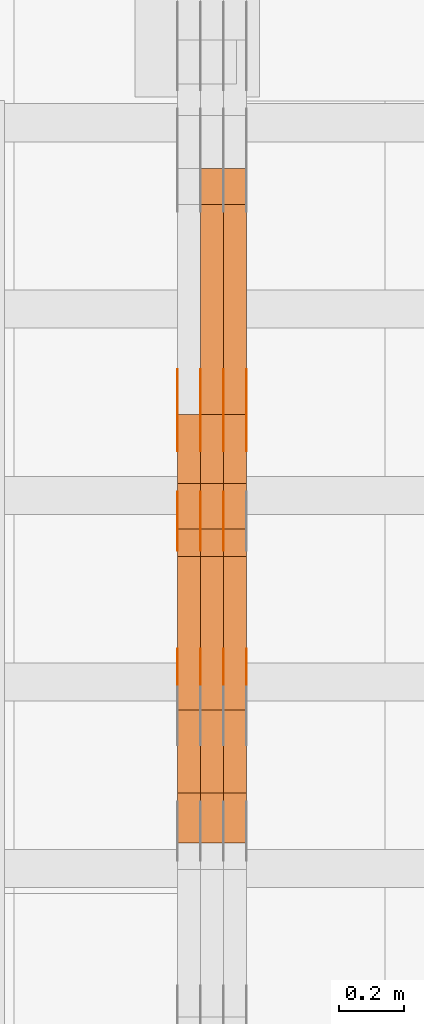
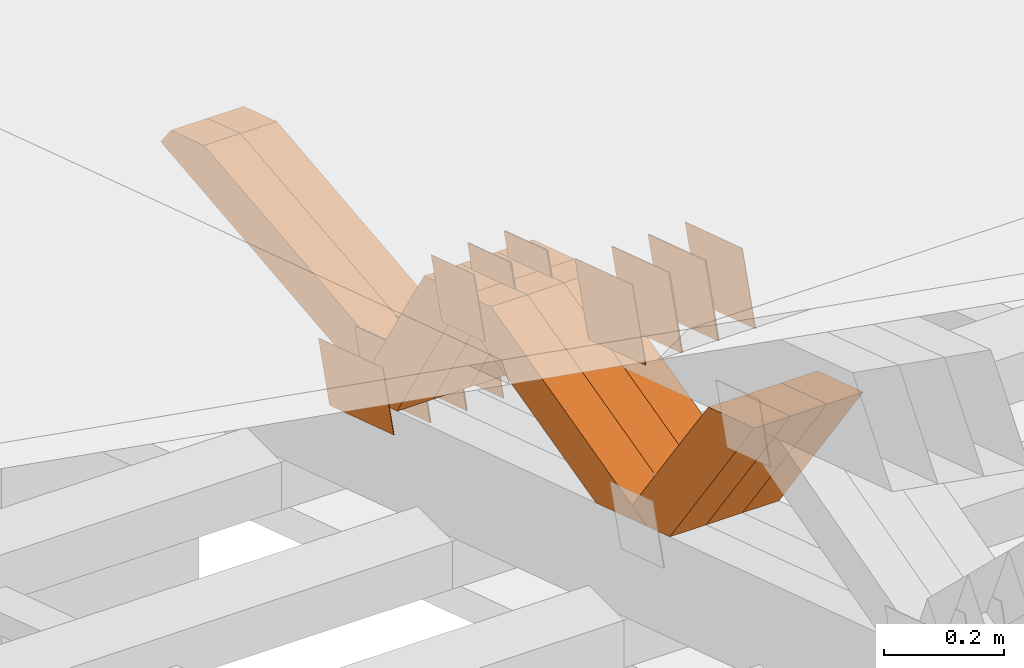
# One storey, part 188 of 385: 28 proxies.
"""IFC2X3 building model written with IfcOpenShell, lengths in millimetres."""

from ifc_helpers import new_model, entity, si_unit, converted_unit, derived_unit, direction, frame, origin, place, context, subcontext, project, spatial, polyline, outline, extrude, source, transform, mapped, material, type_object, type_shapes, element, save


model = new_model("IFC2X3")

# Units and contexts
model_context = context("Model", 3, precision=0.01, world=origin(), true_north=direction((6.12303176911189e-17, 1.0)))
body_context = subcontext(model_context, "Body", "Model", "MODEL_VIEW")
ifc_project = project(units=[si_unit("LENGTHUNIT", "METRE", prefix="MILLI"), si_unit("AREAUNIT", "SQUARE_METRE"), si_unit("VOLUMEUNIT", "CUBIC_METRE"), converted_unit("PLANEANGLEUNIT", "DEGREE", entity("IfcRatioMeasure", 0.0174532925199433), si_unit("PLANEANGLEUNIT", "RADIAN"), dimensions=[0, 0, 0, 0, 0, 0, 0]), si_unit("MASSUNIT", "GRAM", prefix="KILO"), derived_unit("MASSDENSITYUNIT", [(si_unit("MASSUNIT", "GRAM", prefix="KILO"), 1), (si_unit("LENGTHUNIT", "METRE"), -3)]), si_unit("TIMEUNIT", "SECOND"), si_unit("FREQUENCYUNIT", "HERTZ"), si_unit("THERMODYNAMICTEMPERATUREUNIT", "DEGREE_CELSIUS"), derived_unit("THERMALTRANSMITTANCEUNIT", [(si_unit("MASSUNIT", "GRAM", prefix="KILO"), 1), (si_unit("THERMODYNAMICTEMPERATUREUNIT", "KELVIN"), -1), (si_unit("TIMEUNIT", "SECOND"), -3)]), derived_unit("VOLUMETRICFLOWRATEUNIT", [(si_unit("LENGTHUNIT", "METRE"), 3), (si_unit("TIMEUNIT", "SECOND"), -1)]), si_unit("ELECTRICCURRENTUNIT", "AMPERE"), si_unit("ELECTRICVOLTAGEUNIT", "VOLT"), si_unit("POWERUNIT", "WATT"), si_unit("FORCEUNIT", "NEWTON", prefix="KILO"), si_unit("ILLUMINANCEUNIT", "LUX"), si_unit("LUMINOUSFLUXUNIT", "LUMEN"), si_unit("LUMINOUSINTENSITYUNIT", "CANDELA"), derived_unit("USERDEFINED", [(si_unit("MASSUNIT", "GRAM", prefix="KILO"), -1), (si_unit("LENGTHUNIT", "METRE"), -2), (si_unit("TIMEUNIT", "SECOND"), 3), (si_unit("LUMINOUSFLUXUNIT", "LUMEN"), 1)]), derived_unit("LINEARVELOCITYUNIT", [(si_unit("LENGTHUNIT", "METRE"), 1), (si_unit("TIMEUNIT", "SECOND"), -1)]), si_unit("PRESSUREUNIT", "PASCAL"), derived_unit("USERDEFINED", [(si_unit("LENGTHUNIT", "METRE"), -2), (si_unit("MASSUNIT", "GRAM", prefix="KILO"), 1), (si_unit("TIMEUNIT", "SECOND"), -2)])], contexts=[model_context])

# Site, building, storey
site_placement = place(None, origin())
site = spatial("IfcSite", under=ifc_project, at=site_placement, CompositionType="ELEMENT")
building_placement = place(site_placement, origin())
building = spatial("IfcBuilding", under=site, at=building_placement, CompositionType="ELEMENT")
storey_placement = place(building_placement, origin())
storey = spatial("IfcBuildingStorey", under=building, at=storey_placement, Name="Default", CompositionType="ELEMENT", Elevation=0.0)

# Proxies
ifc_material_1 = material(Name="IfcSurfaceStyle #91081")
building_element_proxy_type_1 = type_object("IfcBuildingElementProxyType", PredefinedType="NOTDEFINED", material=ifc_material_1)
shared_shape_1 = source(origin(), body_context, "Body", "SweptSolid", [
    extrude(outline(polyline([(-75.0001163267648, -60.0000309352964), (75.0001029049313, -60.0000309352964), (75.0001068963143, 60.0000309352964), (-75.0000934744807, 60.0000309352964), (-75.0001163267648, -60.0000309352964)])), frame((75.0001143227305, 60.0000309352964, 0.0), z_axis=(0.0, 0.0, 1.0), x_axis=(-1.0, 0.0, 0.0)), (0.0, 0.0, 1.0), 1.3),
])
type_shapes(building_element_proxy_type_1, [shared_shape_1])
proxy_1_placement = place(building_placement, frame((6315.0, 24935.0160969462, 827.753587802763), z_axis=(-1.0, 0.0, 0.0), x_axis=(0.0, -0.951056516295154, 0.309016994374948)))
element("IfcBuildingElementProxy", 1, at=proxy_1_placement, inside=storey, type_object=building_element_proxy_type_1, material=ifc_material_1, context=body_context, shape_type="MappedRepresentation", body=[
    mapped(shared_shape_1, transform((0.0, 0.0, 0.0), scale=1.0)),
])
ifc_material_2 = material(Name="IfcSurfaceStyle #91024")
building_element_proxy_type_2 = type_object("IfcBuildingElementProxyType", PredefinedType="NOTDEFINED", material=ifc_material_2)
shared_shape_2 = source(origin(), body_context, "Body", "SweptSolid", [
    extrude(outline(polyline([(-75.0001163267648, -60.0000309352964), (75.0001029049313, -60.0000309352964), (75.0001068963143, 60.0000309352964), (-75.0000934744807, 60.0000309352964), (-75.0001163267648, -60.0000309352964)])), frame((75.0001143227305, 60.0000309352964, 0.0), z_axis=(0.0, 0.0, 1.0), x_axis=(-1.0, 0.0, 0.0)), (0.0, 0.0, 1.0), 1.3),
])
type_shapes(building_element_proxy_type_2, [shared_shape_2])
proxy_2_placement = place(building_placement, frame((6316.29999999999, 24935.0160969462, 827.753587802763), z_axis=(-1.0, 0.0, 0.0), x_axis=(0.0, -0.951056516295154, 0.309016994374948)))
element("IfcBuildingElementProxy", 2, at=proxy_2_placement, inside=storey, type_object=building_element_proxy_type_2, material=ifc_material_2, context=body_context, shape_type="MappedRepresentation", body=[
    mapped(shared_shape_2, transform((0.0, 0.0, 0.0), scale=1.0)),
])
ifc_material_3 = material(Name="IfcSurfaceStyle #90967")
building_element_proxy_type_3 = type_object("IfcBuildingElementProxyType", PredefinedType="NOTDEFINED", material=ifc_material_3)
shared_shape_3 = source(origin(), body_context, "Body", "SweptSolid", [
    extrude(outline(polyline([(-75.0001163267648, -60.0000309352964), (75.0001029049313, -60.0000309352964), (75.0001068963143, 60.0000309352964), (-75.0000934744807, 60.0000309352964), (-75.0001163267648, -60.0000309352964)])), frame((75.0001143227305, 60.0000309352964, 0.0), z_axis=(0.0, 0.0, 1.0), x_axis=(-1.0, 0.0, 0.0)), (0.0, 0.0, 1.0), 1.29999999999999),
])
type_shapes(building_element_proxy_type_3, [shared_shape_3])
proxy_3_placement = place(building_placement, frame((6245.0, 24935.0160969462, 827.753587802763), z_axis=(-1.0, 0.0, 0.0), x_axis=(0.0, -0.951056516295154, 0.309016994374948)))
element("IfcBuildingElementProxy", 3, at=proxy_3_placement, inside=storey, type_object=building_element_proxy_type_3, material=ifc_material_3, context=body_context, shape_type="MappedRepresentation", body=[
    mapped(shared_shape_3, transform((0.0, 0.0, 0.0), scale=1.0)),
])
ifc_material_4 = material(Name="IfcSurfaceStyle #90910")
building_element_proxy_type_4 = type_object("IfcBuildingElementProxyType", PredefinedType="NOTDEFINED", material=ifc_material_4)
shared_shape_4 = source(origin(), body_context, "Body", "SweptSolid", [
    extrude(outline(polyline([(-75.0001163267648, -60.0000309352964), (75.0001029049313, -60.0000309352964), (75.0001068963143, 60.0000309352964), (-75.0000934744807, 60.0000309352964), (-75.0001163267648, -60.0000309352964)])), frame((75.0001143227305, 60.0000309352964, 0.0), z_axis=(0.0, 0.0, 1.0), x_axis=(-1.0, 0.0, 0.0)), (0.0, 0.0, 1.0), 1.29999999999999),
])
type_shapes(building_element_proxy_type_4, [shared_shape_4])
proxy_4_placement = place(building_placement, frame((6246.29999999999, 24935.0160969462, 827.753587802763), z_axis=(-1.0, 0.0, 0.0), x_axis=(0.0, -0.951056516295154, 0.309016994374948)))
element("IfcBuildingElementProxy", 4, at=proxy_4_placement, inside=storey, type_object=building_element_proxy_type_4, material=ifc_material_4, context=body_context, shape_type="MappedRepresentation", body=[
    mapped(shared_shape_4, transform((0.0, 0.0, 0.0), scale=1.0)),
])
ifc_material_5 = material(Name="IfcSurfaceStyle #90853")
building_element_proxy_type_5 = type_object("IfcBuildingElementProxyType", PredefinedType="NOTDEFINED", material=ifc_material_5)
shared_shape_5 = source(origin(), body_context, "Body", "SweptSolid", [
    extrude(outline(polyline([(-75.0001163267648, -60.0000309352964), (75.0001029049313, -60.0000309352964), (75.0001068963143, 60.0000309352964), (-75.0000934744807, 60.0000309352964), (-75.0001163267648, -60.0000309352964)])), frame((75.0001143227305, 60.0000309352964, 0.0), z_axis=(0.0, 0.0, 1.0), x_axis=(-1.0, 0.0, 0.0)), (0.0, 0.0, 1.0), 1.29999999999999),
])
type_shapes(building_element_proxy_type_5, [shared_shape_5])
proxy_5_placement = place(building_placement, frame((6175.0, 24935.0160969462, 827.753587802763), z_axis=(-1.0, 0.0, 0.0), x_axis=(0.0, -0.951056516295154, 0.309016994374948)))
element("IfcBuildingElementProxy", 5, at=proxy_5_placement, inside=storey, type_object=building_element_proxy_type_5, material=ifc_material_5, context=body_context, shape_type="MappedRepresentation", body=[
    mapped(shared_shape_5, transform((0.0, 0.0, 0.0), scale=1.0)),
])
ifc_material_6 = material(Name="IfcSurfaceStyle #90796")
building_element_proxy_type_6 = type_object("IfcBuildingElementProxyType", PredefinedType="NOTDEFINED", material=ifc_material_6)
shared_shape_6 = source(origin(), body_context, "Body", "SweptSolid", [
    extrude(outline(polyline([(-112.50003853564, -60.0000121429077), (112.50002982902, -60.0000121429077), (112.500043250865, 60.0000121429077), (-112.500034544245, 60.0000121429077), (-112.50003853564, -60.0000121429077)])), frame((112.500056021398, 60.0000121429077, 0.0), z_axis=(0.0, 0.0, 1.0), x_axis=(-1.0, 0.0, 0.0)), (0.0, 0.0, 1.0), 1.3),
])
type_shapes(building_element_proxy_type_6, [shared_shape_6])
proxy_6_placement = place(building_placement, frame((6386.29999999999, 25310.2182710495, 430.675738123044), z_axis=(-1.0, 0.0, 0.0), x_axis=(0.0, -0.951056516295124, 0.309016994375039)))
element("IfcBuildingElementProxy", 6, at=proxy_6_placement, inside=storey, type_object=building_element_proxy_type_6, material=ifc_material_6, context=body_context, shape_type="MappedRepresentation", body=[
    mapped(shared_shape_6, transform((0.0, 0.0, 0.0), scale=1.0)),
])
ifc_material_7 = material(Name="IfcSurfaceStyle #90739")
building_element_proxy_type_7 = type_object("IfcBuildingElementProxyType", PredefinedType="NOTDEFINED", material=ifc_material_7)
shared_shape_7 = source(origin(), body_context, "Body", "SweptSolid", [
    extrude(outline(polyline([(-112.50003853564, -60.0000121429077), (112.50002982902, -60.0000121429077), (112.500043250865, 60.0000121429077), (-112.500034544245, 60.0000121429077), (-112.50003853564, -60.0000121429077)])), frame((112.500056021398, 60.0000121429077, 0.0), z_axis=(0.0, 0.0, 1.0), x_axis=(-1.0, 0.0, 0.0)), (0.0, 0.0, 1.0), 1.3),
])
type_shapes(building_element_proxy_type_7, [shared_shape_7])
proxy_7_placement = place(building_placement, frame((6315.0, 25310.2182710495, 430.675738123044), z_axis=(-1.0, 0.0, 0.0), x_axis=(0.0, -0.951056516295124, 0.309016994375039)))
element("IfcBuildingElementProxy", 7, at=proxy_7_placement, inside=storey, type_object=building_element_proxy_type_7, material=ifc_material_7, context=body_context, shape_type="MappedRepresentation", body=[
    mapped(shared_shape_7, transform((0.0, 0.0, 0.0), scale=1.0)),
])
ifc_material_8 = material(Name="IfcSurfaceStyle #90682")
building_element_proxy_type_8 = type_object("IfcBuildingElementProxyType", PredefinedType="NOTDEFINED", material=ifc_material_8)
shared_shape_8 = source(origin(), body_context, "Body", "SweptSolid", [
    extrude(outline(polyline([(-112.50003853564, -60.0000121429077), (112.50002982902, -60.0000121429077), (112.500043250865, 60.0000121429077), (-112.500034544245, 60.0000121429077), (-112.50003853564, -60.0000121429077)])), frame((112.500056021398, 60.0000121429077, 0.0), z_axis=(0.0, 0.0, 1.0), x_axis=(-1.0, 0.0, 0.0)), (0.0, 0.0, 1.0), 1.3),
])
type_shapes(building_element_proxy_type_8, [shared_shape_8])
proxy_8_placement = place(building_placement, frame((6316.29999999999, 25310.2182710495, 430.675738123044), z_axis=(-1.0, 0.0, 0.0), x_axis=(0.0, -0.951056516295124, 0.309016994375039)))
element("IfcBuildingElementProxy", 8, at=proxy_8_placement, inside=storey, type_object=building_element_proxy_type_8, material=ifc_material_8, context=body_context, shape_type="MappedRepresentation", body=[
    mapped(shared_shape_8, transform((0.0, 0.0, 0.0), scale=1.0)),
])
ifc_material_9 = material(Name="IfcSurfaceStyle #90625")
building_element_proxy_type_9 = type_object("IfcBuildingElementProxyType", PredefinedType="NOTDEFINED", material=ifc_material_9)
shared_shape_9 = source(origin(), body_context, "Body", "SweptSolid", [
    extrude(outline(polyline([(-112.50003853564, -60.0000121429077), (112.50002982902, -60.0000121429077), (112.500043250865, 60.0000121429077), (-112.500034544245, 60.0000121429077), (-112.50003853564, -60.0000121429077)])), frame((112.500056021398, 60.0000121429077, 0.0), z_axis=(0.0, 0.0, 1.0), x_axis=(-1.0, 0.0, 0.0)), (0.0, 0.0, 1.0), 1.29999999999998),
])
type_shapes(building_element_proxy_type_9, [shared_shape_9])
proxy_9_placement = place(building_placement, frame((6245.0, 25310.2182710495, 430.675738123044), z_axis=(-1.0, 0.0, 0.0), x_axis=(0.0, -0.951056516295124, 0.309016994375039)))
element("IfcBuildingElementProxy", 9, at=proxy_9_placement, inside=storey, type_object=building_element_proxy_type_9, material=ifc_material_9, context=body_context, shape_type="MappedRepresentation", body=[
    mapped(shared_shape_9, transform((0.0, 0.0, 0.0), scale=1.0)),
])
ifc_material_10 = material(Name="IfcSurfaceStyle #90568")
building_element_proxy_type_10 = type_object("IfcBuildingElementProxyType", PredefinedType="NOTDEFINED", material=ifc_material_10)
shared_shape_10 = source(origin(), body_context, "Body", "SweptSolid", [
    extrude(outline(polyline([(-112.50003853564, -60.0000121429077), (112.50002982902, -60.0000121429077), (112.500043250865, 60.0000121429077), (-112.500034544245, 60.0000121429077), (-112.50003853564, -60.0000121429077)])), frame((112.500056021398, 60.0000121429077, 0.0), z_axis=(0.0, 0.0, 1.0), x_axis=(-1.0, 0.0, 0.0)), (0.0, 0.0, 1.0), 1.29999999999998),
])
type_shapes(building_element_proxy_type_10, [shared_shape_10])
proxy_10_placement = place(building_placement, frame((6246.29999999999, 25310.2182710495, 430.675738123044), z_axis=(-1.0, 0.0, 0.0), x_axis=(0.0, -0.951056516295124, 0.309016994375039)))
element("IfcBuildingElementProxy", 10, at=proxy_10_placement, inside=storey, type_object=building_element_proxy_type_10, material=ifc_material_10, context=body_context, shape_type="MappedRepresentation", body=[
    mapped(shared_shape_10, transform((0.0, 0.0, 0.0), scale=1.0)),
])
ifc_material_11 = material(Name="IfcSurfaceStyle #90511")
building_element_proxy_type_11 = type_object("IfcBuildingElementProxyType", PredefinedType="NOTDEFINED", material=ifc_material_11)
shared_shape_11 = source(origin(), body_context, "Body", "SweptSolid", [
    extrude(outline(polyline([(-112.50003853564, -60.0000121429077), (112.50002982902, -60.0000121429077), (112.500043250865, 60.0000121429077), (-112.500034544245, 60.0000121429077), (-112.50003853564, -60.0000121429077)])), frame((112.500056021398, 60.0000121429077, 0.0), z_axis=(0.0, 0.0, 1.0), x_axis=(-1.0, 0.0, 0.0)), (0.0, 0.0, 1.0), 1.29999999999999),
])
type_shapes(building_element_proxy_type_11, [shared_shape_11])
proxy_11_placement = place(building_placement, frame((6175.0, 25310.2182710495, 430.675738123044), z_axis=(-1.0, 0.0, 0.0), x_axis=(0.0, -0.951056516295124, 0.309016994375039)))
element("IfcBuildingElementProxy", 11, at=proxy_11_placement, inside=storey, type_object=building_element_proxy_type_11, material=ifc_material_11, context=body_context, shape_type="MappedRepresentation", body=[
    mapped(shared_shape_11, transform((0.0, 0.0, 0.0), scale=1.0)),
])
ifc_material_12 = material(Name="IfcSurfaceStyle #88744")
building_element_proxy_type_12 = type_object("IfcBuildingElementProxyType", PredefinedType="NOTDEFINED", material=ifc_material_12)
shared_shape_12 = source(origin(), body_context, "Body", "SweptSolid", [
    extrude(outline(polyline([(-100.000009625089, -72.0000630699202), (100.000090167682, -72.0000630699202), (100.000009625089, 72.0000630699202), (-100.000090167682, 72.0000630699202), (-100.000009625089, -72.0000630699202)])), frame((100.000090167682, 72.0000630699202, 0.0), z_axis=(0.0, 0.0, 1.0), x_axis=(-1.0, 0.0, 0.0)), (0.0, 0.0, 1.0), 1.3),
])
type_shapes(building_element_proxy_type_12, [shared_shape_12])
proxy_12_placement = place(building_placement, frame((6386.29999999999, 24447.7695802369, 1088.58717039832), z_axis=(-1.0, 0.0, 0.0), x_axis=(0.0, -0.951056516295154, 0.309016994374948)))
element("IfcBuildingElementProxy", 12, at=proxy_12_placement, inside=storey, type_object=building_element_proxy_type_12, material=ifc_material_12, context=body_context, shape_type="MappedRepresentation", body=[
    mapped(shared_shape_12, transform((0.0, 0.0, 0.0), scale=1.0)),
])
ifc_material_13 = material(Name="IfcSurfaceStyle #88687")
building_element_proxy_type_13 = type_object("IfcBuildingElementProxyType", PredefinedType="NOTDEFINED", material=ifc_material_13)
shared_shape_13 = source(origin(), body_context, "Body", "SweptSolid", [
    extrude(outline(polyline([(-100.000009625089, -72.0000630699202), (100.000090167682, -72.0000630699202), (100.000009625089, 72.0000630699202), (-100.000090167682, 72.0000630699202), (-100.000009625089, -72.0000630699202)])), frame((100.000090167682, 72.0000630699202, 0.0), z_axis=(0.0, 0.0, 1.0), x_axis=(-1.0, 0.0, 0.0)), (0.0, 0.0, 1.0), 1.3),
])
type_shapes(building_element_proxy_type_13, [shared_shape_13])
proxy_13_placement = place(building_placement, frame((6315.0, 24447.7695802369, 1088.58717039832), z_axis=(-1.0, 0.0, 0.0), x_axis=(0.0, -0.951056516295154, 0.309016994374948)))
element("IfcBuildingElementProxy", 13, at=proxy_13_placement, inside=storey, type_object=building_element_proxy_type_13, material=ifc_material_13, context=body_context, shape_type="MappedRepresentation", body=[
    mapped(shared_shape_13, transform((0.0, 0.0, 0.0), scale=1.0)),
])
ifc_material_14 = material(Name="IfcSurfaceStyle #88630")
building_element_proxy_type_14 = type_object("IfcBuildingElementProxyType", PredefinedType="NOTDEFINED", material=ifc_material_14)
shared_shape_14 = source(origin(), body_context, "Body", "SweptSolid", [
    extrude(outline(polyline([(-100.000009625089, -72.0000630699202), (100.000090167682, -72.0000630699202), (100.000009625089, 72.0000630699202), (-100.000090167682, 72.0000630699202), (-100.000009625089, -72.0000630699202)])), frame((100.000090167682, 72.0000630699202, 0.0), z_axis=(0.0, 0.0, 1.0), x_axis=(-1.0, 0.0, 0.0)), (0.0, 0.0, 1.0), 1.3),
])
type_shapes(building_element_proxy_type_14, [shared_shape_14])
proxy_14_placement = place(building_placement, frame((6316.29999999999, 24447.7695802369, 1088.58717039832), z_axis=(-1.0, 0.0, 0.0), x_axis=(0.0, -0.951056516295154, 0.309016994374948)))
element("IfcBuildingElementProxy", 14, at=proxy_14_placement, inside=storey, type_object=building_element_proxy_type_14, material=ifc_material_14, context=body_context, shape_type="MappedRepresentation", body=[
    mapped(shared_shape_14, transform((0.0, 0.0, 0.0), scale=1.0)),
])
ifc_material_15 = material(Name="IfcSurfaceStyle #88573")
building_element_proxy_type_15 = type_object("IfcBuildingElementProxyType", PredefinedType="NOTDEFINED", material=ifc_material_15)
shared_shape_15 = source(origin(), body_context, "Body", "SweptSolid", [
    extrude(outline(polyline([(-100.000009625089, -72.0000630699202), (100.000090167682, -72.0000630699202), (100.000009625089, 72.0000630699202), (-100.000090167682, 72.0000630699202), (-100.000009625089, -72.0000630699202)])), frame((100.000090167682, 72.0000630699202, 0.0), z_axis=(0.0, 0.0, 1.0), x_axis=(-1.0, 0.0, 0.0)), (0.0, 0.0, 1.0), 1.29999999999998),
])
type_shapes(building_element_proxy_type_15, [shared_shape_15])
proxy_15_placement = place(building_placement, frame((6245.0, 24447.7695802369, 1088.58717039832), z_axis=(-1.0, 0.0, 0.0), x_axis=(0.0, -0.951056516295154, 0.309016994374948)))
element("IfcBuildingElementProxy", 15, at=proxy_15_placement, inside=storey, type_object=building_element_proxy_type_15, material=ifc_material_15, context=body_context, shape_type="MappedRepresentation", body=[
    mapped(shared_shape_15, transform((0.0, 0.0, 0.0), scale=1.0)),
])
ifc_material_16 = material(Name="IfcSurfaceStyle #88516")
building_element_proxy_type_16 = type_object("IfcBuildingElementProxyType", PredefinedType="NOTDEFINED", material=ifc_material_16)
shared_shape_16 = source(origin(), body_context, "Body", "SweptSolid", [
    extrude(outline(polyline([(-100.000009625089, -72.0000630699202), (100.000090167682, -72.0000630699202), (100.000009625089, 72.0000630699202), (-100.000090167682, 72.0000630699202), (-100.000009625089, -72.0000630699202)])), frame((100.000090167682, 72.0000630699202, 0.0), z_axis=(0.0, 0.0, 1.0), x_axis=(-1.0, 0.0, 0.0)), (0.0, 0.0, 1.0), 1.29999999999998),
])
type_shapes(building_element_proxy_type_16, [shared_shape_16])
proxy_16_placement = place(building_placement, frame((6246.29999999999, 24447.7695802369, 1088.58717039832), z_axis=(-1.0, 0.0, 0.0), x_axis=(0.0, -0.951056516295154, 0.309016994374948)))
element("IfcBuildingElementProxy", 16, at=proxy_16_placement, inside=storey, type_object=building_element_proxy_type_16, material=ifc_material_16, context=body_context, shape_type="MappedRepresentation", body=[
    mapped(shared_shape_16, transform((0.0, 0.0, 0.0), scale=1.0)),
])
ifc_material_17 = material(Name="IfcSurfaceStyle #88459")
building_element_proxy_type_17 = type_object("IfcBuildingElementProxyType", PredefinedType="NOTDEFINED", material=ifc_material_17)
shared_shape_17 = source(origin(), body_context, "Body", "SweptSolid", [
    extrude(outline(polyline([(-100.000009625089, -72.0000630699202), (100.000090167682, -72.0000630699202), (100.000009625089, 72.0000630699202), (-100.000090167682, 72.0000630699202), (-100.000009625089, -72.0000630699202)])), frame((100.000090167682, 72.0000630699202, 0.0), z_axis=(0.0, 0.0, 1.0), x_axis=(-1.0, 0.0, 0.0)), (0.0, 0.0, 1.0), 1.29999999999999),
])
type_shapes(building_element_proxy_type_17, [shared_shape_17])
proxy_17_placement = place(building_placement, frame((6175.0, 24447.7695802369, 1088.58717039832), z_axis=(-1.0, 0.0, 0.0), x_axis=(0.0, -0.951056516295154, 0.309016994374948)))
element("IfcBuildingElementProxy", 17, at=proxy_17_placement, inside=storey, type_object=building_element_proxy_type_17, material=ifc_material_17, context=body_context, shape_type="MappedRepresentation", body=[
    mapped(shared_shape_17, transform((0.0, 0.0, 0.0), scale=1.0)),
])
ifc_material_18 = material(Name="IfcSurfaceStyle #79546")
building_element_proxy_type_18 = type_object("IfcBuildingElementProxyType", Name="T1-W24 79544", PredefinedType="NOTDEFINED", material=ifc_material_18)
shared_shape_18 = source(origin(), body_context, "Body", "SweptSolid", [
    extrude(outline(polyline([(-215.642157779899, -47.4998772343114), (220.829928576248, -47.4998772343114), (202.182343865616, 6.34871490324596e-05), (137.545638852774, 47.4998454907369), (-344.915753514738, 47.4998454907369), (-215.642157779899, -47.4998772343114)])), frame((220.830079609702, 47.500154567531, 0.0), z_axis=(0.0, 0.0, 1.0), x_axis=(-1.0, 0.0, 0.0)), (0.0, 0.0, 1.0), 70.0),
])
type_shapes(building_element_proxy_type_18, [shared_shape_18])
proxy_18_placement = place(building_placement, frame((6385.0, 24227.7045444998, 781.019082122604), z_axis=(-1.0, 0.0, 0.0), x_axis=(0.0, -0.583381854128324, 0.812198012970851)))
element("IfcBuildingElementProxy", 18, at=proxy_18_placement, inside=storey, type_object=building_element_proxy_type_18, material=ifc_material_18, Name="T1-W24", context=body_context, shape_type="MappedRepresentation", body=[
    mapped(shared_shape_18, transform((0.0, 0.0, 0.0), scale=1.0)),
])
ifc_material_19 = material(Name="IfcSurfaceStyle #79480")
building_element_proxy_type_19 = type_object("IfcBuildingElementProxyType", Name="T1-W24 79478", PredefinedType="NOTDEFINED", material=ifc_material_19)
shared_shape_19 = source(origin(), body_context, "Body", "SweptSolid", [
    extrude(outline(polyline([(-215.642157779899, -47.4998772343114), (220.829928576248, -47.4998772343114), (202.182343865616, 6.34871490324596e-05), (137.545638852774, 47.4998454907369), (-344.915753514738, 47.4998454907369), (-215.642157779899, -47.4998772343114)])), frame((220.830079609702, 47.500154567531, 0.0), z_axis=(0.0, 0.0, 1.0), x_axis=(-1.0, 0.0, 0.0)), (0.0, 0.0, 1.0), 70.0),
])
type_shapes(building_element_proxy_type_19, [shared_shape_19])
proxy_19_placement = place(building_placement, frame((6315.0, 24227.7045444998, 781.019082122604), z_axis=(-1.0, 0.0, 0.0), x_axis=(0.0, -0.583381854128324, 0.812198012970851)))
element("IfcBuildingElementProxy", 19, at=proxy_19_placement, inside=storey, type_object=building_element_proxy_type_19, material=ifc_material_19, Name="T1-W24", context=body_context, shape_type="MappedRepresentation", body=[
    mapped(shared_shape_19, transform((0.0, 0.0, 0.0), scale=1.0)),
])
ifc_material_20 = material(Name="IfcSurfaceStyle #79414")
building_element_proxy_type_20 = type_object("IfcBuildingElementProxyType", Name="T1-W24 79412", PredefinedType="NOTDEFINED", material=ifc_material_20)
shared_shape_20 = source(origin(), body_context, "Body", "SweptSolid", [
    extrude(outline(polyline([(-215.642157779899, -47.4998772343114), (220.829928576248, -47.4998772343114), (202.182343865616, 6.34871490324596e-05), (137.545638852774, 47.4998454907369), (-344.915753514738, 47.4998454907369), (-215.642157779899, -47.4998772343114)])), frame((220.830079609702, 47.500154567531, 0.0), z_axis=(0.0, 0.0, 1.0), x_axis=(-1.0, 0.0, 0.0)), (0.0, 0.0, 1.0), 70.0),
])
type_shapes(building_element_proxy_type_20, [shared_shape_20])
proxy_20_placement = place(building_placement, frame((6245.0, 24227.7045444998, 781.019082122604), z_axis=(-1.0, 0.0, 0.0), x_axis=(0.0, -0.583381854128324, 0.812198012970851)))
element("IfcBuildingElementProxy", 20, at=proxy_20_placement, inside=storey, type_object=building_element_proxy_type_20, material=ifc_material_20, Name="T1-W24", context=body_context, shape_type="MappedRepresentation", body=[
    mapped(shared_shape_20, transform((0.0, 0.0, 0.0), scale=1.0)),
])
ifc_material_21 = material(Name="IfcSurfaceStyle #79150")
building_element_proxy_type_21 = type_object("IfcBuildingElementProxyType", Name="T1-W13 79148", PredefinedType="NOTDEFINED", material=ifc_material_21)
shared_shape_21 = source(origin(), body_context, "Body", "SweptSolid", [
    extrude(outline(polyline([(-384.339592151497, -47.5000055308246), (150.996422207105, -47.5000055308247), (226.265349299398, -4.29484466835994e-05), (240.878612116891, 47.500027005048), (-233.800791471897, 47.500027005048), (-384.339592151497, -47.5000055308246)])), frame((240.878612116891, 47.500027005048, 0.0), z_axis=(0.0, 0.0, 1.0), x_axis=(-1.0, 0.0, 0.0)), (0.0, 0.0, 1.0), 70.0),
])
type_shapes(building_element_proxy_type_21, [shared_shape_21])
proxy_21_placement = place(building_placement, frame((6385.0, 24884.765625, 885.749145507813), z_axis=(-1.0, 0.0, 0.0), x_axis=(0.0, -0.969210894563555, -0.246232089418326)))
element("IfcBuildingElementProxy", 21, at=proxy_21_placement, inside=storey, type_object=building_element_proxy_type_21, material=ifc_material_21, Name="T1-W13", context=body_context, shape_type="MappedRepresentation", body=[
    mapped(shared_shape_21, transform((0.0, 0.0, 0.0), scale=1.0)),
])
ifc_material_22 = material(Name="IfcSurfaceStyle #79084")
building_element_proxy_type_22 = type_object("IfcBuildingElementProxyType", Name="T1-W13 79082", PredefinedType="NOTDEFINED", material=ifc_material_22)
shared_shape_22 = source(origin(), body_context, "Body", "SweptSolid", [
    extrude(outline(polyline([(-384.339592151497, -47.5000055308246), (150.996422207105, -47.5000055308247), (226.265349299398, -4.29484466835994e-05), (240.878612116891, 47.500027005048), (-233.800791471897, 47.500027005048), (-384.339592151497, -47.5000055308246)])), frame((240.878612116891, 47.500027005048, 0.0), z_axis=(0.0, 0.0, 1.0), x_axis=(-1.0, 0.0, 0.0)), (0.0, 0.0, 1.0), 70.0),
])
type_shapes(building_element_proxy_type_22, [shared_shape_22])
proxy_22_placement = place(building_placement, frame((6315.0, 24884.765625, 885.749145507813), z_axis=(-1.0, 0.0, 0.0), x_axis=(0.0, -0.969210894563555, -0.246232089418326)))
element("IfcBuildingElementProxy", 22, at=proxy_22_placement, inside=storey, type_object=building_element_proxy_type_22, material=ifc_material_22, Name="T1-W13", context=body_context, shape_type="MappedRepresentation", body=[
    mapped(shared_shape_22, transform((0.0, 0.0, 0.0), scale=1.0)),
])
ifc_material_23 = material(Name="IfcSurfaceStyle #79018")
building_element_proxy_type_23 = type_object("IfcBuildingElementProxyType", Name="T1-W13 79016", PredefinedType="NOTDEFINED", material=ifc_material_23)
shared_shape_23 = source(origin(), body_context, "Body", "SweptSolid", [
    extrude(outline(polyline([(-384.339592151497, -47.5000055308246), (150.996422207105, -47.5000055308247), (226.265349299398, -4.29484466835994e-05), (240.878612116891, 47.500027005048), (-233.800791471897, 47.500027005048), (-384.339592151497, -47.5000055308246)])), frame((240.878612116891, 47.500027005048, 0.0), z_axis=(0.0, 0.0, 1.0), x_axis=(-1.0, 0.0, 0.0)), (0.0, 0.0, 1.0), 70.0),
])
type_shapes(building_element_proxy_type_23, [shared_shape_23])
proxy_23_placement = place(building_placement, frame((6245.0, 24884.765625, 885.749145507813), z_axis=(-1.0, 0.0, 0.0), x_axis=(0.0, -0.969210894563555, -0.246232089418326)))
element("IfcBuildingElementProxy", 23, at=proxy_23_placement, inside=storey, type_object=building_element_proxy_type_23, material=ifc_material_23, Name="T1-W13", context=body_context, shape_type="MappedRepresentation", body=[
    mapped(shared_shape_23, transform((0.0, 0.0, 0.0), scale=1.0)),
])
ifc_material_24 = material(Name="IfcSurfaceStyle #78754")
building_element_proxy_type_24 = type_object("IfcBuildingElementProxyType", Name="T1-W31 78752", PredefinedType="NOTDEFINED", material=ifc_material_24)
shared_shape_24 = source(origin(), body_context, "Body", "SweptSolid", [
    extrude(outline(polyline([(-201.245318299844, -47.5000121670808), (204.413774229459, -47.5000121670808), (182.034306640891, 5.35692244583164e-05), (126.70380769348, 47.4999853824686), (-311.906570263987, 47.4999853824686), (-201.245318299844, -47.5000121670808)])), frame((204.413774229459, 47.5002684334588, 0.0), z_axis=(0.0, 0.0, 1.0), x_axis=(-1.0, 0.0, 0.0)), (0.0, 0.0, 1.0), 70.0),
])
type_shapes(building_element_proxy_type_24, [shared_shape_24])
proxy_24_placement = place(building_placement, frame((6385.0, 25127.5652647985, 487.27008059185), z_axis=(-1.0, 0.0, 0.0), x_axis=(0.0, -0.520333970303023, 0.853962855953755)))
element("IfcBuildingElementProxy", 24, at=proxy_24_placement, inside=storey, type_object=building_element_proxy_type_24, material=ifc_material_24, Name="T1-W31", context=body_context, shape_type="MappedRepresentation", body=[
    mapped(shared_shape_24, transform((0.0, 0.0, 0.0), scale=1.0)),
])
ifc_material_25 = material(Name="IfcSurfaceStyle #78688")
building_element_proxy_type_25 = type_object("IfcBuildingElementProxyType", Name="T1-W31 78686", PredefinedType="NOTDEFINED", material=ifc_material_25)
shared_shape_25 = source(origin(), body_context, "Body", "SweptSolid", [
    extrude(outline(polyline([(-201.245318299844, -47.5000121670808), (204.413774229459, -47.5000121670808), (182.034306640891, 5.35692244583164e-05), (126.70380769348, 47.4999853824686), (-311.906570263987, 47.4999853824686), (-201.245318299844, -47.5000121670808)])), frame((204.413774229459, 47.5002684334588, 0.0), z_axis=(0.0, 0.0, 1.0), x_axis=(-1.0, 0.0, 0.0)), (0.0, 0.0, 1.0), 70.0),
])
type_shapes(building_element_proxy_type_25, [shared_shape_25])
proxy_25_placement = place(building_placement, frame((6315.0, 25127.5652647985, 487.27008059185), z_axis=(-1.0, 0.0, 0.0), x_axis=(0.0, -0.520333970303023, 0.853962855953755)))
element("IfcBuildingElementProxy", 25, at=proxy_25_placement, inside=storey, type_object=building_element_proxy_type_25, material=ifc_material_25, Name="T1-W31", context=body_context, shape_type="MappedRepresentation", body=[
    mapped(shared_shape_25, transform((0.0, 0.0, 0.0), scale=1.0)),
])
ifc_material_26 = material(Name="IfcSurfaceStyle #78622")
building_element_proxy_type_26 = type_object("IfcBuildingElementProxyType", Name="T1-W31 78620", PredefinedType="NOTDEFINED", material=ifc_material_26)
shared_shape_26 = source(origin(), body_context, "Body", "SweptSolid", [
    extrude(outline(polyline([(-201.245318299844, -47.5000121670808), (204.413774229459, -47.5000121670808), (182.034306640891, 5.35692244583164e-05), (126.70380769348, 47.4999853824686), (-311.906570263987, 47.4999853824686), (-201.245318299844, -47.5000121670808)])), frame((204.413774229459, 47.5002684334588, 0.0), z_axis=(0.0, 0.0, 1.0), x_axis=(-1.0, 0.0, 0.0)), (0.0, 0.0, 1.0), 70.0),
])
type_shapes(building_element_proxy_type_26, [shared_shape_26])
proxy_26_placement = place(building_placement, frame((6245.0, 25127.5652647985, 487.27008059185), z_axis=(-1.0, 0.0, 0.0), x_axis=(0.0, -0.520333970303023, 0.853962855953755)))
element("IfcBuildingElementProxy", 26, at=proxy_26_placement, inside=storey, type_object=building_element_proxy_type_26, material=ifc_material_26, Name="T1-W31", context=body_context, shape_type="MappedRepresentation", body=[
    mapped(shared_shape_26, transform((0.0, 0.0, 0.0), scale=1.0)),
])
ifc_material_27 = material(Name="IfcSurfaceStyle #78358")
building_element_proxy_type_27 = type_object("IfcBuildingElementProxyType", Name="T1-W4 78356", PredefinedType="NOTDEFINED", material=ifc_material_27)
shared_shape_27 = source(origin(), body_context, "Body", "SweptSolid", [
    extrude(outline(polyline([(-510.077325435179, -47.4999981284922), (188.854793418912, -47.4999981284922), (294.906688207675, 1.67015383116809e-05), (324.289382923648, 47.499989777723), (-297.973539115057, 47.4999897777231), (-510.077325435179, -47.4999981284922)])), frame((324.289382923648, 47.5000278316275, 0.0), z_axis=(0.0, 0.0, 1.0), x_axis=(-1.0, 0.0, 0.0)), (0.0, 0.0, 1.0), 70.0),
])
type_shapes(building_element_proxy_type_27, [shared_shape_27])
proxy_27_placement = place(building_placement, frame((6385.0, 25996.2241251556, 525.69905884318), z_axis=(-1.0, 0.0, 0.0), x_axis=(0.0, -0.994287125203057, -0.106738524701444)))
element("IfcBuildingElementProxy", 27, at=proxy_27_placement, inside=storey, type_object=building_element_proxy_type_27, material=ifc_material_27, Name="T1-W4", context=body_context, shape_type="MappedRepresentation", body=[
    mapped(shared_shape_27, transform((0.0, 0.0, 0.0), scale=1.0)),
])
ifc_material_28 = material(Name="IfcSurfaceStyle #78292")
building_element_proxy_type_28 = type_object("IfcBuildingElementProxyType", Name="T1-W4 78290", PredefinedType="NOTDEFINED", material=ifc_material_28)
shared_shape_28 = source(origin(), body_context, "Body", "SweptSolid", [
    extrude(outline(polyline([(-510.077325435179, -47.4999981284922), (188.854793418912, -47.4999981284922), (294.906688207675, 1.67015383116809e-05), (324.289382923648, 47.499989777723), (-297.973539115057, 47.4999897777231), (-510.077325435179, -47.4999981284922)])), frame((324.289382923648, 47.5000278316275, 0.0), z_axis=(0.0, 0.0, 1.0), x_axis=(-1.0, 0.0, 0.0)), (0.0, 0.0, 1.0), 70.0),
])
type_shapes(building_element_proxy_type_28, [shared_shape_28])
proxy_28_placement = place(building_placement, frame((6315.0, 25996.2241251556, 525.69905884318), z_axis=(-1.0, 0.0, 0.0), x_axis=(0.0, -0.994287125203057, -0.106738524701444)))
element("IfcBuildingElementProxy", 28, at=proxy_28_placement, inside=storey, type_object=building_element_proxy_type_28, material=ifc_material_28, Name="T1-W4", context=body_context, shape_type="MappedRepresentation", body=[
    mapped(shared_shape_28, transform((0.0, 0.0, 0.0), scale=1.0)),
])

save(model, "model.ifc")
